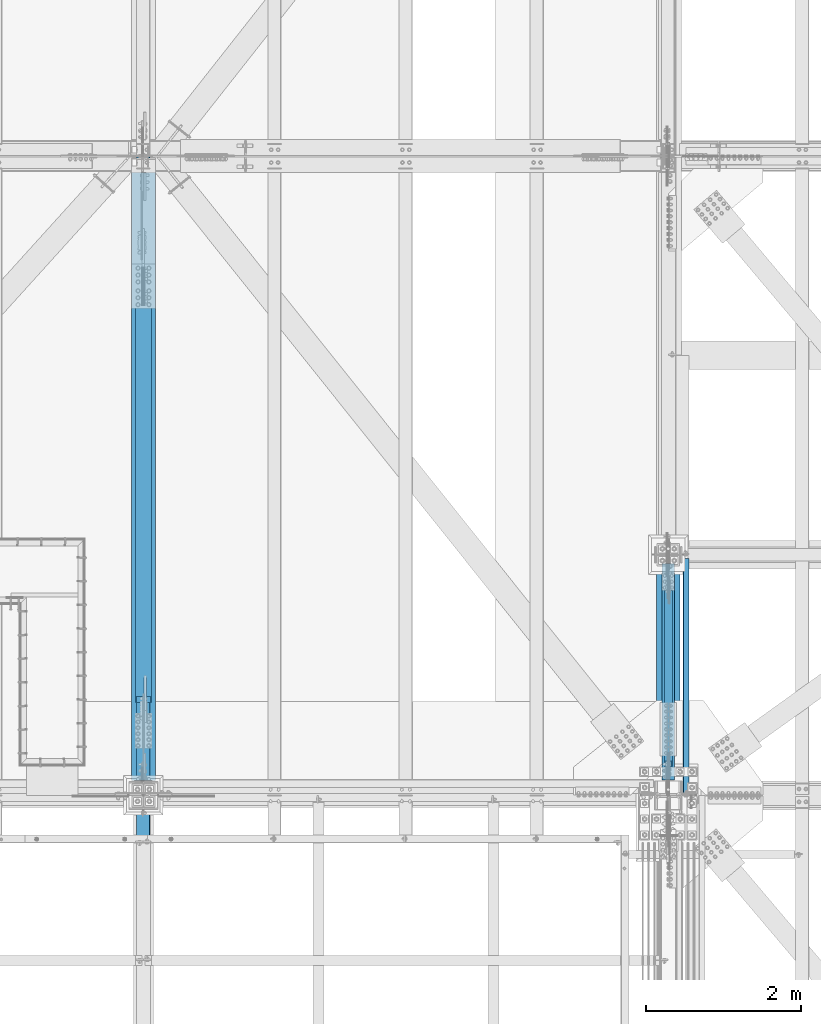
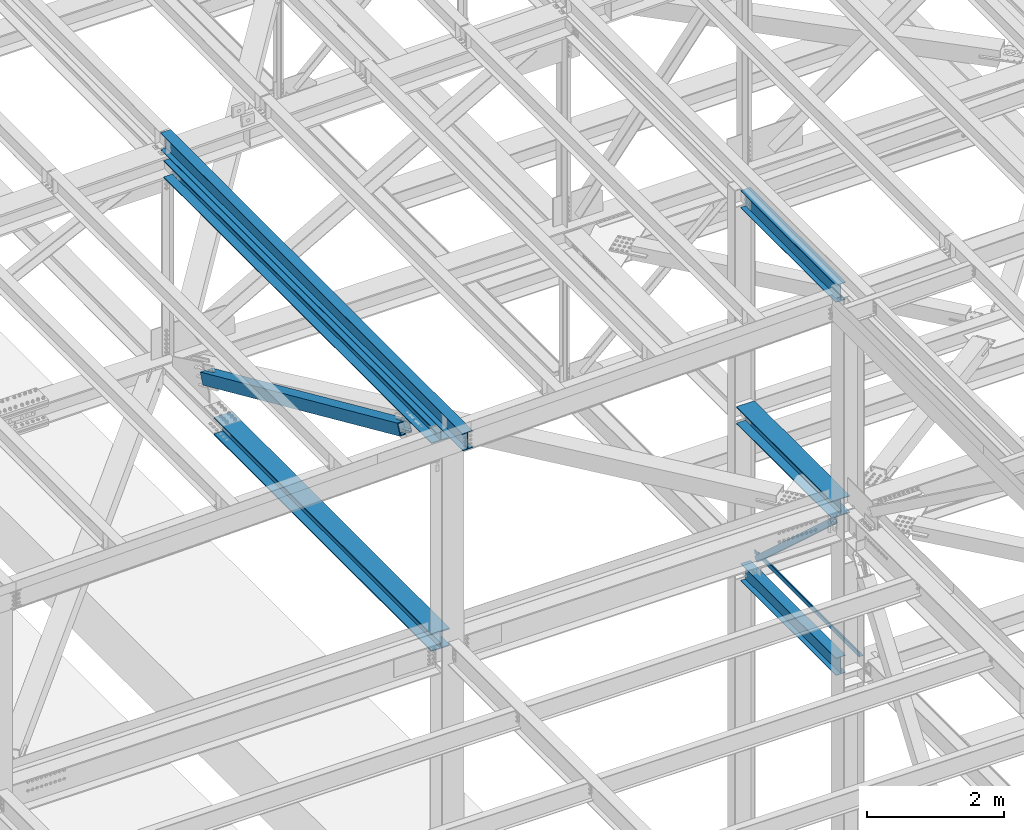
# One storey, part 1801 of 3843: 7 beams, 2 members, 9 elements without a shape of their own.
"""IFC2X3 building model written with IfcOpenShell, lengths in millimetres."""

from ifc_helpers import new_model, si_unit, frame, origin_with_axes, place, context, subcontext, project, spatial, faceted_brep, material, type_object, element, aggregate, save


model = new_model("IFC2X3")

# Units and contexts
model_context = context("Model", 3, precision=1e-05, world=origin_with_axes())
body_context = subcontext(model_context, "Body", "Model", "MODEL_VIEW")
ifc_project = project(units=[si_unit("LENGTHUNIT", "METRE", prefix="MILLI"), si_unit("AREAUNIT", "SQUARE_METRE"), si_unit("VOLUMEUNIT", "CUBIC_METRE"), si_unit("MASSUNIT", "GRAM", prefix="KILO"), si_unit("TIMEUNIT", "SECOND"), si_unit("PLANEANGLEUNIT", "RADIAN"), si_unit("SOLIDANGLEUNIT", "STERADIAN"), si_unit("THERMODYNAMICTEMPERATUREUNIT", "DEGREE_CELSIUS"), si_unit("LUMINOUSINTENSITYUNIT", "LUMEN")], contexts=[model_context])

# Site, building, storey
site_placement = place(None, origin_with_axes())
site = spatial("IfcSite", under=ifc_project, at=site_placement, CompositionType="ELEMENT")
building_placement = place(site_placement, origin_with_axes())
building = spatial("IfcBuilding", under=site, at=building_placement, Name="Undefined", CompositionType="ELEMENT")
storey_placement = place(building_placement, origin_with_axes())
storey = spatial("IfcBuildingStorey", under=building, at=storey_placement, Name="Undefined", CompositionType="ELEMENT", Elevation=0.0)

# Assembly, beam
assembly_1_placement = place(storey_placement, origin_with_axes())
assembly_1 = element("IfcElementAssembly", 1, at=assembly_1_placement, inside=storey, Name="BEAM", AssemblyPlace="NOTDEFINED", PredefinedType="RIGID_FRAME")
ifc_material_1 = material(Name="STEEL/A992")
beam_type_1 = type_object("IfcBeamType", Name="W12X26", PredefinedType="NOTDEFINED")
beam_1_placement = place(assembly_1_placement, frame((77012.8000002526, 25615.9, 46076.9955507418), z_axis=(0.0, 0.0, 1.0), x_axis=(0.0, 1.0, 0.0)))
beam_1 = element("IfcBeam", 2, at=beam_1_placement, type_object=beam_type_1, material=ifc_material_1, Name="BEAM", ObjectType="W12X26", context=body_context, shape_type="Brep", body=[
    faceted_brep([(196.849999999984, -82.5500000000029, -155.574999999997), (196.849999999984, 82.5500000000029, -155.574999999997), (2984.5, 82.5500000000029, -155.574999999997), (2984.5, -82.5500000000029, -155.574999999997), (196.849999999984, -82.5500000000029, -146.050000000003), (196.849999999984, -3.17500000000291, -146.050000000003), (196.849999999984, -3.17500000000291, 146.050000000003), (196.849999999984, -82.5500000000029, 146.050000000003), (196.849999999984, -82.5500000000029, 155.574999999997), (196.849999999984, 82.5500000000029, 155.574999999997), (196.849999999984, 82.5500000000029, 146.050000000003), (196.849999999984, 3.17500000000291, 146.050000000003), (196.849999999984, 3.17500000000291, 118.21499999892), (196.849999999984, 3.17500000000291, -124.564999999908), (196.849999999984, 3.17500000000291, -146.050000000003), (196.849999999984, 82.5500000000029, -146.050000000003), (2984.5, -82.5500000000029, -146.050000000003), (2984.5, -3.17500000000291, -146.050000000003), (2984.5, -3.17500000000291, 146.050000000003), (2984.5, -82.5500000000029, 146.050000000003), (2984.5, -82.5500000000029, 155.574999999997), (2984.5, 82.5500000000029, 155.574999999997), (2984.5, 82.5500000000029, 146.050000000003), (2984.5, 3.17500000000291, 146.050000000003), (2984.5, 3.17500000000291, 118.214999998927), (2984.5, 3.17500000000291, -124.5649999999), (2984.5, 3.17500000000291, -146.050000000003), (2984.5, 82.5500000000029, -146.050000000003)], [[[0, 1, 2, 3]], [[0, 4, 5, 6, 7, 8, 9, 10, 11, 12, 13, 14, 15, 1]], [[5, 4, 16, 17]], [[6, 5, 17, 18]], [[7, 6, 18, 19]], [[8, 7, 19, 20]], [[9, 8, 20, 21]], [[10, 9, 21, 22]], [[11, 10, 22, 23]], [[14, 13, 12, 11, 23, 24, 25, 26]], [[15, 14, 26, 27]], [[1, 15, 27, 2]], [[26, 25, 24, 23, 22, 21, 20, 19, 18, 17, 16, 3, 2, 27]], [[4, 0, 3, 16]]]),
])
aggregate(assembly_1, [beam_1])

assembly_2_placement = place(storey_placement, origin_with_axes())
assembly_2 = element("IfcElementAssembly", 3, at=assembly_2_placement, inside=storey, Name="BEAM", AssemblyPlace="NOTDEFINED", PredefinedType="RIGID_FRAME")
beam_2_placement = place(assembly_2_placement, frame((70253.1092622703, 25006.014051209, 46286.4854782954), z_axis=(-0.0211520977514447, -0.0018380119996873, 0.999774579829175), x_axis=(0.0, 0.999998310099008, 0.00183842300018168)))
beam_2 = element("IfcBeam", 4, at=beam_2_placement, type_object=beam_type_1, material=ifc_material_1, Name="BEAM", ObjectType="W12X26", context=body_context, shape_type="Brep", body=[
    faceted_brep([(0.0, 82.5500000000029, -155.574999999997), (0.0, 82.5500000000029, -146.050000000003), (8826.5292130925, 82.5500000010506, -146.050000012059), (8826.51170600161, 82.5500000010943, -155.575000012053), (0.0, 3.17500000000291, -146.050000000003), (8826.53229971384, 3.17500000062864, -146.050000011834), (0.0, 3.17500000000291, 146.050000000003), (8827.06918383486, 3.1749999998865, 146.049999988158), (0.0, 82.5500000000029, 146.050000000003), (8827.06609721354, 82.5500000003231, 146.049999987932), (0.0, 82.5500000000029, 155.574999999997), (8827.08360430443, 82.5500000002939, 155.574999987926), (0.0, -82.5500000000029, 155.574999999997), (8827.09002447681, -82.5500000006141, 155.574999988392), (0.0, -82.5500000000029, 146.050000000003), (8827.0725173859, -82.5500000005704, 146.049999988398), (0.0, -3.17500000000291, 146.050000000003), (8827.06943076458, -3.17500000014843, 146.049999988179), (0.0, -3.17500000000291, -146.050000000003), (8826.53254664355, -3.17499999940628, -146.050000011819), (0.0, -82.5500000000029, -146.050000000003), (8826.53563326488, -82.5499999998428, -146.050000011594), (0.0, -82.5500000000029, -155.574999999997), (8826.51812617397, -82.5499999998283, -155.575000011588)], [[[0, 1, 2, 3]], [[1, 4, 5, 2]], [[4, 6, 7, 5]], [[6, 8, 9, 7]], [[8, 10, 11, 9]], [[10, 12, 13, 11]], [[12, 14, 15, 13]], [[14, 16, 17, 15]], [[16, 18, 19, 17]], [[18, 20, 21, 19]], [[20, 22, 23, 21]], [[22, 0, 3, 23]], [[5, 7, 9, 11, 13, 15, 17, 19, 21, 23, 3, 2]], [[22, 20, 18, 16, 14, 12, 10, 8, 6, 4, 1, 0]]]),
])
aggregate(assembly_2, [beam_2])

assembly_3_placement = place(storey_placement, origin_with_axes())
assembly_3 = element("IfcElementAssembly", 5, at=assembly_3_placement, inside=storey, Name="BEAM", AssemblyPlace="NOTDEFINED", PredefinedType="RIGID_FRAME")
beam_3_placement = place(assembly_3_placement, frame((77012.8, 25615.9, 39423.975), z_axis=(0.0, 0.0, 1.0), x_axis=(0.0, 1.0, 0.0)))
beam_3 = element("IfcBeam", 6, at=beam_3_placement, type_object=beam_type_1, material=ifc_material_1, Name="BEAM", ObjectType="W12X26", context=body_context, shape_type="Brep", body=[
    faceted_brep([(196.849999999984, -82.5500000000029, -155.574999999997), (196.849999999984, 82.5500000000029, -155.574999999997), (2984.5, 82.5500000000029, -155.574999999997), (2984.5, -82.5500000000029, -155.574999999997), (196.849999999984, -82.5500000000029, -146.050000000003), (196.849999999984, -3.17500000000291, -146.050000000003), (196.850000000006, -3.17500000000291, -111.864999999998), (196.850000000006, -3.17500000000291, 118.214999999997), (196.849999999984, -3.17500000000291, 146.050000000003), (196.849999999984, -82.5500000000029, 146.050000000003), (196.849999999984, -82.5500000000029, 155.574999999997), (196.849999999984, 82.5500000000029, 155.574999999997), (196.849999999984, 82.5500000000029, 146.050000000003), (196.849999999984, 3.17500000000291, 146.050000000003), (196.849999999984, 3.17500000000291, -146.050000000003), (196.849999999984, 82.5500000000029, -146.050000000003), (2984.5, -82.5500000000029, -146.050000000003), (2984.5, -3.17500000000291, -146.050000000003), (2984.50000000001, -3.17500000000291, -111.864999999998), (2984.50000000001, -3.17500000000291, 118.214999999997), (2984.5, -3.17500000000291, 146.050000000003), (2984.5, -82.5500000000029, 146.050000000003), (2984.5, -82.5500000000029, 155.574999999997), (2984.5, 82.5500000000029, 155.574999999997), (2984.5, 82.5500000000029, 146.050000000003), (2984.5, 3.17500000000291, 146.050000000003), (2984.5, 3.17500000000291, -146.050000000003), (2984.5, 82.5500000000029, -146.050000000003)], [[[0, 1, 2, 3]], [[0, 4, 5, 6, 7, 8, 9, 10, 11, 12, 13, 14, 15, 1]], [[5, 4, 16, 17]], [[8, 7, 6, 5, 17, 18, 19, 20]], [[9, 8, 20, 21]], [[10, 9, 21, 22]], [[11, 10, 22, 23]], [[12, 11, 23, 24]], [[13, 12, 24, 25]], [[14, 13, 25, 26]], [[15, 14, 26, 27]], [[1, 15, 27, 2]], [[26, 25, 24, 23, 22, 21, 20, 19, 18, 17, 16, 3, 2, 27]], [[4, 0, 3, 16]]]),
])
aggregate(assembly_3, [beam_3])

assembly_4_placement = place(storey_placement, origin_with_axes())
assembly_4 = element("IfcElementAssembly", 7, at=assembly_4_placement, inside=storey, Name="BENT_PLATE", AssemblyPlace="NOTDEFINED", PredefinedType="RIGID_FRAME")
ifc_material_2 = material(Name="STEEL/A36")
beam_type_2 = type_object("IfcBeamType", PredefinedType="NOTDEFINED")
beam_4_placement = place(assembly_4_placement, frame((77279.5000000002, 27139.9, 39627.1749999997), z_axis=(0.0, 1.0, 0.0), x_axis=(-1.0, 0.0, 0.0)))
beam_4 = element("IfcBeam", 8, at=beam_4_placement, type_object=beam_type_2, material=ifc_material_2, Name="BENT_PLATE", context=body_context, shape_type="Brep", body=[
    faceted_brep([(0.0, -3.17500000000291, -1524.0), (0.0, -3.17500000000291, 1524.0), (0.0, 3.17500000000291, 1524.0), (0.0, 3.17500000000291, -1524.0), (69.8500000002387, 3.17500000000291, 1524.0), (69.8500000002387, 3.17500000000291, -1524.0), (76.2000000002299, -3.17500000000291, -1524.0), (76.2000000002299, -3.17500000000291, 1524.0), (69.8500000003114, 73.0249999997832, 1524.0), (69.8500000003114, 73.0249999997832, -1524.0), (76.2000000003172, 73.0249999997686, 1524.0), (76.2000000003172, 73.0249999997686, -1524.0)], [[[0, 1, 2, 3]], [[3, 2, 4, 5]], [[1, 0, 6, 7]], [[5, 4, 8, 9]], [[4, 2, 1, 7, 10, 8]], [[7, 6, 11, 10]], [[6, 0, 3, 5, 9, 11]], [[10, 11, 9, 8]]]),
])
aggregate(assembly_4, [beam_4])

# Assembly, member
assembly_5_placement = place(storey_placement, origin_with_axes())
assembly_5 = element("IfcElementAssembly", 9, at=assembly_5_placement, inside=storey, AssemblyPlace="NOTDEFINED", PredefinedType="RIGID_FRAME")
ifc_material_3 = material()
member_type_1 = type_object("IfcMemberType", Name="HSS4X4X3/8", PredefinedType="NOTDEFINED")
member_1_placement = place(assembly_5_placement, frame((77012.8, 25615.9, 42246.55), z_axis=(1.0, 0.0, 0.0), x_axis=(0.0, 0.739288510044847, -0.673388817040846)))
member_1 = element("IfcMember", 10, at=member_1_placement, type_object=member_type_1, material=ifc_material_3, ObjectType="HSS4X4X3/8", context=body_context, shape_type="Brep", body=[
    faceted_brep([(3521.58607597838, -50.8000000018219, 4.76249999999709), (3521.58607597841, -41.2750000018423, 4.76249999999709), (3421.57357597422, -41.2750000017841, 4.76249999999709), (3421.57357597417, -50.800000001771, 4.76249999999709), (3418.53602622981, -41.2750000017841, 5.36670621068333), (3418.53602622976, -50.800000001771, 5.36670621068333), (3415.96091589853, -41.2750000017841, 7.08733992432826), (3415.96091589848, -50.8000000017637, 7.08733992432826), (3414.24028218489, -41.2750000017841, 9.66245025559328), (3414.24028218483, -50.8000000017637, 9.66245025559328), (3413.63607597419, -41.2750000017841, 12.6999999999971), (3413.63607597414, -50.8000000017637, 12.6999999999971), (3414.24028218489, -41.2750000017841, 15.7375497444009), (3414.24028218483, -50.8000000017637, 15.7375497444009), (3415.96091589853, -41.2750000017841, 18.3126600756659), (3415.96091589848, -50.8000000017637, 18.3126600756659), (3418.53602622981, -41.2750000017841, 20.0332937893108), (3418.53602622976, -50.800000001771, 20.0332937893108), (3421.57357597422, -41.2750000017841, 20.6374999999971), (3421.57357597417, -50.800000001771, 20.6374999999971), (3521.58607597838, -50.8000000018219, 20.6374999999971), (3521.58607597841, -41.2750000018423, 20.6374999999971), (3521.58607597861, 41.2749999980297, 4.76249999999709), (3521.58607597864, 50.7999999980093, 4.76249999999709), (3421.57357597472, 50.7999999980675, 4.76249999999709), (3421.57357597467, 41.2749999980806, 4.76249999999709), (3418.53602623031, 50.7999999980675, 5.36670621068333), (3418.53602623026, 41.2749999980879, 5.36670621068333), (3415.96091589903, 50.7999999980675, 7.08733992432826), (3415.96091589898, 41.2749999980879, 7.08733992432826), (3414.24028218539, 50.7999999980675, 9.66245025559328), (3414.24028218533, 41.2749999980879, 9.66245025559328), (3413.63607597469, 50.7999999980748, 12.6999999999971), (3413.63607597464, 41.2749999980879, 12.6999999999971), (3414.24028218539, 50.7999999980675, 15.7375497444009), (3414.24028218533, 41.2749999980879, 15.7375497444009), (3415.96091589903, 50.7999999980675, 18.3126600756659), (3415.96091589898, 41.2749999980879, 18.3126600756659), (3418.53602623031, 50.7999999980675, 20.0332937893108), (3418.53602623026, 41.2749999980879, 20.0332937893108), (3421.57357597472, 50.7999999980675, 20.6374999999971), (3421.57357597467, 41.2749999980806, 20.6374999999971), (3521.58607597861, 41.2749999980297, 20.6374999999971), (3521.58607597864, 50.7999999980093, 20.6374999999971), (554.495127844564, -41.275000000227, 41.2749999999942), (554.495127844764, 41.2749999996449, 41.2749999999942), (3521.58607597861, 41.2749999980297, 41.2749999999942), (3521.58607597841, -41.2750000018423, 41.2749999999942), (3521.58607597841, -41.2750000018423, -41.2749999999942), (554.495127844564, -41.275000000227, -41.2749999999942), (554.495127844564, -41.275000000227, 4.76249999999709), (654.507627846315, -41.2750000002852, 4.76249999999709), (657.545177590726, -41.2750000002852, 5.36670621068333), (660.120287921998, -41.2750000002852, 7.08733992432826), (661.840921635647, -41.2750000002852, 9.66245025559328), (662.445127846344, -41.2750000002852, 12.6999999999971), (661.840921635647, -41.2750000002852, 15.7375497444009), (660.120287921998, -41.2750000002852, 18.3126600756659), (657.545177590726, -41.2750000002852, 20.0332937893108), (654.507627846315, -41.2750000002852, 20.6374999999971), (554.495127844564, -41.275000000227, 20.6374999999971), (554.495127844764, 41.2749999996449, -41.2749999999942), (3521.58607597861, 41.2749999980297, -41.2749999999942), (554.495127844764, 41.2749999996449, 20.6374999999971), (554.495127844786, 50.7999999996246, 20.6374999999971), (654.507627846817, 50.7999999995664, 20.6374999999971), (654.507627846762, 41.2749999995867, 20.6374999999971), (657.545177591224, 50.7999999995664, 20.0332937893108), (657.545177591173, 41.2749999995867, 20.0332937893108), (660.1202879225, 50.7999999995664, 18.3126600756659), (660.120287922449, 41.2749999995867, 18.3126600756659), (661.840921636145, 50.7999999995664, 15.7375497444009), (661.840921636094, 41.2749999995867, 15.7375497444009), (662.445127846839, 50.7999999995664, 12.6999999999971), (662.445127846795, 41.2749999995794, 12.6999999999971), (661.840921636145, 50.7999999995664, 9.66245025559328), (661.840921636094, 41.2749999995867, 9.66245025559328), (660.1202879225, 50.7999999995664, 7.08733992432826), (660.120287922449, 41.2749999995867, 7.08733992432826), (657.545177591224, 50.7999999995664, 5.36670621068333), (657.545177591173, 41.2749999995867, 5.36670621068333), (654.507627846817, 50.7999999995664, 4.76249999999709), (654.507627846762, 41.2749999995867, 4.76249999999709), (554.495127844786, 50.7999999996246, 4.76249999999709), (554.495127844764, 41.2749999996449, 4.76249999999709), (554.495127844786, 50.7999999996246, -50.8000000000029), (554.495127844542, -50.8000000002139, -50.8000000000029), (554.495127844542, -50.8000000002139, 4.76249999999709), (654.50762784626, -50.8000000002648, 4.76249999999709), (657.545177590671, -50.8000000002648, 5.36670621068333), (660.120287921947, -50.8000000002648, 7.08733992432826), (661.840921635599, -50.8000000002794, 9.66245025559328), (662.445127846289, -50.8000000002721, 12.6999999999971), (661.840921635599, -50.8000000002794, 15.7375497444009), (660.120287921947, -50.8000000002648, 18.3126600756659), (657.545177590671, -50.8000000002648, 20.0332937893108), (654.50762784626, -50.8000000002648, 20.6374999999971), (554.495127844542, -50.8000000002139, 20.6374999999971), (554.495127844542, -50.8000000002139, 50.8000000000029), (554.495127844786, 50.7999999996246, 50.8000000000029), (3521.58607597838, -50.8000000018219, 50.8000000000029), (3521.58607597864, 50.7999999980093, 50.8000000000029), (3521.58607597864, 50.7999999980093, -50.8000000000029), (3521.58607597838, -50.8000000018219, -50.8000000000029)], [[[0, 1, 2, 3]], [[3, 2, 4, 5]], [[5, 4, 6, 7]], [[7, 6, 8, 9]], [[9, 8, 10, 11]], [[11, 10, 12, 13]], [[13, 12, 14, 15]], [[15, 14, 16, 17]], [[17, 16, 18, 19]], [[20, 19, 18, 21]], [[22, 23, 24, 25]], [[25, 24, 26, 27]], [[27, 26, 28, 29]], [[29, 28, 30, 31]], [[31, 30, 32, 33]], [[33, 32, 34, 35]], [[35, 34, 36, 37]], [[37, 36, 38, 39]], [[39, 38, 40, 41]], [[42, 41, 40, 43]], [[44, 45, 46, 47]], [[16, 14, 12, 10, 8, 6, 4, 2, 1, 48, 49, 50, 51, 52, 53, 54, 55, 56, 57, 58, 59, 60, 44, 47, 21, 18]], [[61, 49, 48, 62]], [[63, 64, 65, 66]], [[66, 65, 67, 68]], [[68, 67, 69, 70]], [[70, 69, 71, 72]], [[72, 71, 73, 74]], [[74, 73, 75, 76]], [[76, 75, 77, 78]], [[78, 77, 79, 80]], [[80, 79, 81, 82]], [[82, 81, 83, 84]], [[49, 61, 84, 83, 85, 86, 87, 50]], [[88, 51, 50, 87]], [[89, 52, 51, 88]], [[90, 53, 52, 89]], [[91, 54, 53, 90]], [[92, 55, 54, 91]], [[93, 56, 55, 92]], [[94, 57, 56, 93]], [[95, 58, 57, 94]], [[96, 59, 58, 95]], [[97, 60, 59, 96]], [[98, 99, 64, 63, 45, 44, 60, 97]], [[99, 98, 100, 101]], [[47, 46, 42, 43, 101, 100, 20, 21]], [[38, 36, 34, 32, 30, 28, 26, 24, 23, 102, 85, 83, 81, 79, 77, 75, 73, 71, 69, 67, 65, 64, 99, 101, 43, 40]], [[86, 85, 102, 103]], [[100, 98, 97, 96, 95, 94, 93, 92, 91, 90, 89, 88, 87, 86, 103, 0, 3, 5, 7, 9, 11, 13, 15, 17, 19, 20]], [[103, 102, 23, 22, 62, 48, 1, 0]], [[46, 45, 63, 66, 68, 70, 72, 74, 76, 78, 80, 82, 84, 61, 62, 22, 25, 27, 29, 31, 33, 35, 37, 39, 41, 42]]]),
])
aggregate(assembly_5, [member_1])

# Assembly, beam
assembly_6_placement = place(storey_placement, origin_with_axes())
assembly_6 = element("IfcElementAssembly", 11, at=assembly_6_placement, inside=storey, Name="BEAM", AssemblyPlace="NOTDEFINED", PredefinedType="RIGID_FRAME")
beam_type_3 = type_object("IfcBeamType", Name="W12X79", PredefinedType="NOTDEFINED")
beam_5_placement = place(assembly_6_placement, frame((70256.4, 25615.8999999924, 42246.5500038407), z_axis=(0.0, -0.00197596299957513, 0.999998047783207), x_axis=(0.0, 0.999998047783207, 0.00197596299957832)))
beam_5 = element("IfcBeam", 12, at=beam_5_placement, type_object=beam_type_3, material=ifc_material_1, Name="BEAM", ObjectType="W12X79", context=body_context, shape_type="Brep", body=[
    faceted_brep([(190.227466467022, -153.987500000003, -138.11249999993), (190.189824336496, -153.987500000003, -157.16249999994), (6546.86279347326, -153.987500000003, -157.162499994578), (6546.86279343517, -153.987500000003, -138.11249999456), (190.227466467022, -6.35000000000582, -138.11249999993), (6546.86279343517, -6.35000000000582, -138.11249999456), (190.773277359673, -6.35000000000582, 138.112500000258), (6546.86279288272, -6.35000000000582, 138.112500005613), (190.773277359673, -153.987500000003, 138.112500000258), (6546.86279288272, -153.987500000003, 138.112500005613), (190.810919490199, -153.987500000003, 157.16250000026), (6546.86279284462, -153.987500000003, 157.16250000563), (190.810919490199, 153.987500000003, 157.16250000026), (6546.86279284462, 153.987500000003, 157.16250000563), (190.773277359673, 153.987500000003, 138.112500000258), (6546.86279288272, 153.987500000003, 138.112500005613), (190.773277359673, 6.35000000000582, 138.112500000258), (6546.86279288272, 6.35000000000582, 138.112500005613), (190.227466467022, 6.35000000000582, -138.11249999993), (6546.86279343517, 6.35000000000582, -138.11249999456), (190.227466467022, 153.987500000003, -138.11249999993), (6546.86279343517, 153.987500000003, -138.11249999456), (190.189824336496, 153.987500000003, -157.16249999994), (6546.86279347326, 153.987500000003, -157.162499994578)], [[[0, 1, 2, 3]], [[4, 0, 3, 5]], [[6, 4, 5, 7]], [[8, 6, 7, 9]], [[10, 8, 9, 11]], [[12, 10, 11, 13]], [[14, 12, 13, 15]], [[16, 14, 15, 17]], [[18, 16, 17, 19]], [[20, 18, 19, 21]], [[1, 0, 4, 6, 8, 10, 12, 14, 16, 18, 20, 22]], [[1, 22, 23, 2]], [[19, 17, 15, 13, 11, 9, 7, 5, 3, 2, 23, 21]], [[22, 20, 21, 23]]]),
])
aggregate(assembly_6, [beam_5])

# Assembly, member
assembly_7_placement = place(storey_placement, origin_with_axes())
assembly_7 = element("IfcElementAssembly", 13, at=assembly_7_placement, inside=storey, AssemblyPlace="NOTDEFINED", PredefinedType="RIGID_FRAME")
member_type_2 = type_object("IfcMemberType", Name="HSS8X8X1/2", PredefinedType="NOTDEFINED")
member_2_placement = place(assembly_7_placement, frame((70256.4, 33845.5, 42262.8114042285), z_axis=(-1.0, 0.0, 0.0), x_axis=(0.0, -0.912577307944657, 0.408904214975198)))
member_2 = element("IfcMember", 14, at=member_2_placement, type_object=member_type_2, material=ifc_material_3, ObjectType="HSS8X8X1/2", context=body_context, shape_type="Brep", body=[
    faceted_brep([(1347.67603524624, -101.599999995481, 17.4624999999942), (1347.67603524629, -88.8999999954694, 17.4624999999942), (1600.08853561316, -88.8999999946036, 17.4624999999942), (1600.08853561313, -101.599999994623, 17.4624999999942), (1606.77114490473, -88.8999999945745, 16.1332463655126), (1606.77114490472, -101.599999994593, 16.1332463655126), (1612.4363875097, -88.8999999945599, 12.3478522781952), (1612.43638750968, -101.599999994579, 12.3478522781952), (1616.22178159695, -88.8999999945454, 6.68260967315291), (1616.22178159691, -101.599999994564, 6.68260967315291), (1600.08853561313, -101.599999994623, -17.4624999999942), (1600.08853561316, -88.8999999946036, -17.4624999999942), (1347.67603524629, -88.8999999954694, -17.4624999999942), (1347.67603524624, -101.599999995481, -17.4624999999942), (1606.77114490472, -101.599999994593, -16.1332463655126), (1606.77114490473, -88.8999999945745, -16.1332463655126), (1612.43638750968, -101.599999994579, -12.3478522781952), (1612.4363875097, -88.8999999945599, -12.3478522781952), (1616.22178159691, -101.599999994564, -6.68260967315291), (1616.22178159695, -88.8999999945454, -6.68260967315291), (1617.55103523137, -101.599999994557, 3.81463905796409e-07), (1617.5510352314, -88.8999999945381, 3.81463905796409e-07), (1347.6760352468, 88.900000004759, 17.4624999999942), (1347.67603524686, 101.600000004771, 17.4624999999942), (1600.08853561363, 101.600000005644, 17.4624999999942), (1600.0885356136, 88.9000000056249, 17.4624999999942), (1606.77114490523, 101.600000005658, 16.1332463655126), (1606.7711449052, 88.9000000056467, 16.1332463655126), (1612.43638751017, 101.600000005687, 12.3478522781952), (1612.43638751014, 88.9000000056612, 12.3478522781952), (1616.22178159743, 101.600000005702, 6.68260967315291), (1616.2217815974, 88.9000000056758, 6.68260967315291), (1600.0885356136, 88.9000000056249, -17.4624999999942), (1600.08853561363, 101.600000005644, -17.4624999999942), (1347.67603524686, 101.600000004771, -17.4624999999942), (1347.6760352468, 88.900000004759, -17.4624999999942), (1606.7711449052, 88.9000000056467, -16.1332463655126), (1606.77114490523, 101.600000005658, -16.1332463655126), (1612.43638751014, 88.9000000056612, -12.3478522781952), (1612.43638751017, 101.600000005687, -12.3478522781952), (1616.2217815974, 88.9000000056758, -6.68260967315291), (1616.22178159743, 101.600000005702, -6.68260967315291), (1617.55103523187, 88.9000000056758, 3.81463905796409e-07), (1617.5510352319, 101.600000005702, 3.81463905796409e-07), (1347.67603524629, -88.8999999954694, 88.8999999999942), (1347.6760352468, 88.900000004759, 88.8999999999942), (7664.35287926906, 88.9000000265069, 88.8999999999942), (7664.35287926854, -88.8999999737289, 88.8999999999942), (1347.67603524686, 101.600000004771, 101.600000000006), (7664.35287926911, 101.600000026511, 101.600000000006), (7664.35292589612, 101.599999979975, -6.35000000000582), (7411.94042551481, 101.599999980623, -6.35000000000582), (7405.25781622318, 101.599999980637, -7.6792536344874), (7399.59257361819, 101.599999980652, -11.4646477218048), (7395.8071795309, 101.599999980666, -17.1298903268471), (7394.47792589643, 101.599999980666, -23.8125003814639), (7395.8071795309, 101.599999980666, -30.4951096731529), (7399.59257361819, 101.599999980652, -36.1603522781952), (7405.25781622318, 101.599999980637, -39.9457463655126), (7411.94042551481, 101.599999980623, -41.2749999999942), (7664.35292589612, 101.599999979975, -41.2749999999942), (7664.35287926911, 101.600000026511, -101.600000000006), (1347.67603524686, 101.600000004771, -101.600000000006), (7664.35292589612, 88.8999999799998, -6.35000000000582), (7411.94042551483, 88.8999999806547, -6.35000000000582), (7405.25781622319, 88.8999999806765, -7.6792536344874), (7399.5925736182, 88.8999999806838, -11.4646477218048), (7395.80717953091, 88.8999999806911, -17.1298903268471), (7394.47792589644, 88.8999999806983, -23.8125003814639), (7395.80717953091, 88.8999999806911, -30.4951096731529), (7399.5925736182, 88.8999999806838, -36.1603522781952), (7405.25781622319, 88.8999999806765, -39.9457463655126), (7411.94042551483, 88.8999999806547, -41.2749999999942), (7664.35292589612, 88.8999999799998, -41.2749999999942), (1347.6760352468, 88.900000004759, -88.8999999999942), (1347.67603524629, -88.8999999954694, -88.8999999999942), (7664.35287926854, -88.8999999737289, -88.8999999999942), (7664.35287926906, 88.9000000265069, -88.8999999999942), (7405.25781622333, -101.600000018792, -7.6792536344874), (7405.25781622332, -88.9000000188244, -7.6792536344874), (7411.94042551496, -88.9000000188462, -6.35000000000582), (7411.94042551496, -101.600000018807, -6.35000000000582), (7399.59257361834, -101.600000018771, -11.4646477218048), (7399.59257361833, -88.9000000188171, -11.4646477218048), (7395.80717953106, -101.600000018763, -17.1298903268471), (7395.80717953105, -88.9000000188025, -17.1298903268471), (7394.47792589658, -101.600000018763, -23.8125003814639), (7394.47792589657, -88.9000000187953, -23.8125003814639), (7395.80717953106, -101.600000018763, -30.4951096731529), (7395.80717953105, -88.9000000188025, -30.4951096731529), (7399.59257361834, -101.600000018771, -36.1603522781952), (7399.59257361833, -88.9000000188171, -36.1603522781952), (7405.25781622333, -101.600000018792, -39.9457463655126), (7405.25781622332, -88.9000000188244, -39.9457463655126), (7411.94042551496, -101.600000018807, -41.2749999999942), (7411.94042551496, -88.9000000188462, -41.2749999999942), (7664.35292589612, -101.600000019454, -41.2749999999942), (7664.35292589612, -88.9000000194937, -41.2749999999942), (7664.35287926851, -101.599999973741, -101.600000000006), (1347.67603524624, -101.599999995481, -101.600000000006), (7664.35292589612, -88.9000000194937, -6.35000000000582), (7664.35292589612, -101.600000019454, -6.35000000000582), (7664.35287926851, -101.599999973741, 101.600000000006), (1347.67603524624, -101.599999995481, 101.600000000006)], [[[0, 1, 2, 3]], [[3, 2, 4, 5]], [[5, 4, 6, 7]], [[7, 6, 8, 9]], [[10, 11, 12, 13]], [[14, 15, 11, 10]], [[16, 17, 15, 14]], [[18, 19, 17, 16]], [[20, 21, 19, 18]], [[9, 8, 21, 20]], [[22, 23, 24, 25]], [[25, 24, 26, 27]], [[27, 26, 28, 29]], [[29, 28, 30, 31]], [[32, 33, 34, 35]], [[36, 37, 33, 32]], [[38, 39, 37, 36]], [[40, 41, 39, 38]], [[42, 43, 41, 40]], [[31, 30, 43, 42]], [[44, 45, 46, 47]], [[28, 26, 24, 23, 48, 49, 50, 51, 52, 53, 54, 55, 56, 57, 58, 59, 60, 61, 62, 34, 33, 37, 39, 41, 43, 30]], [[63, 64, 51, 50]], [[65, 52, 51, 64]], [[66, 53, 52, 65]], [[67, 54, 53, 66]], [[68, 55, 54, 67]], [[69, 56, 55, 68]], [[70, 57, 56, 69]], [[71, 58, 57, 70]], [[72, 59, 58, 71]], [[73, 60, 59, 72]], [[74, 75, 76, 77]], [[78, 79, 80, 81]], [[82, 83, 79, 78]], [[84, 85, 83, 82]], [[86, 87, 85, 84]], [[88, 89, 87, 86]], [[90, 91, 89, 88]], [[92, 93, 91, 90]], [[94, 95, 93, 92]], [[96, 97, 95, 94]], [[98, 61, 60, 73, 77, 76, 97, 96]], [[99, 62, 61, 98]], [[75, 74, 35, 34, 62, 99, 13, 12]], [[6, 4, 2, 1, 44, 47, 100, 80, 79, 83, 85, 87, 89, 91, 93, 95, 97, 76, 75, 12, 11, 15, 17, 19, 21, 8]], [[101, 81, 80, 100]], [[47, 46, 63, 50, 49, 102, 101, 100]], [[48, 103, 102, 49]], [[16, 14, 10, 13, 99, 98, 96, 94, 92, 90, 88, 86, 84, 82, 78, 81, 101, 102, 103, 0, 3, 5, 7, 9, 20, 18]], [[103, 48, 23, 22, 45, 44, 1, 0]], [[38, 36, 32, 35, 74, 77, 73, 72, 71, 70, 69, 68, 67, 66, 65, 64, 63, 46, 45, 22, 25, 27, 29, 31, 42, 40]]]),
])
aggregate(assembly_7, [member_2])

# Assembly, beam
assembly_8_placement = place(storey_placement, origin_with_axes())
assembly_8 = element("IfcElementAssembly", 15, at=assembly_8_placement, inside=storey, Name="BEAM", AssemblyPlace="NOTDEFINED", PredefinedType="RIGID_FRAME")
beam_type_4 = type_object("IfcBeamType", Name="W12X65", PredefinedType="NOTDEFINED")
beam_6_placement = place(assembly_8_placement, frame((70256.4, 25615.9000000006, 45950.2996849465), z_axis=(0.0, 0.0, 1.0), x_axis=(0.0, 1.0, 0.0)))
beam_6 = element("IfcBeam", 16, at=beam_6_placement, type_object=beam_type_4, material=ifc_material_1, Name="BEAM", ObjectType="W12X65", context=body_context, shape_type="Brep", body=[
    faceted_brep([(190.499999998636, -152.399999999994, -138.112500000003), (190.499999998636, -152.399999999994, -153.987500000003), (8016.87499999944, -152.399999999994, -153.987500000003), (8016.87499999944, -152.399999999994, -138.112500000003), (190.499999998636, -4.76249999999709, -138.112500000003), (8016.87499999944, -4.76249999999709, -138.112500000003), (190.499999998636, -4.76249999999709, 138.112500000003), (8016.87499999944, -4.76249999999709, 138.112500000003), (190.499999998636, -152.399999999994, 138.112500000003), (8016.87499999944, -152.399999999994, 138.112500000003), (190.499999998636, -152.399999999994, 153.987500000003), (8016.87499999944, -152.399999999994, 153.987500000003), (190.499999998636, 152.399999999994, 153.987500000003), (8016.87499999944, 152.399999999994, 153.987500000003), (190.499999998636, 152.399999999994, 138.112500000003), (8016.87499999944, 152.399999999994, 138.112500000003), (190.499999998636, 4.76249999999709, 138.112500000003), (8016.87499999944, 4.76249999999709, 138.112500000003), (190.499999998636, 4.76249999999709, -138.112500000003), (8016.87499999944, 4.76249999999709, -138.112500000003), (190.499999998636, 152.399999999994, -138.112500000003), (8016.87499999944, 152.399999999994, -138.112500000003), (190.499999998636, 152.399999999994, -153.987500000003), (8016.87499999944, 152.399999999994, -153.987500000003)], [[[0, 1, 2, 3]], [[4, 0, 3, 5]], [[6, 4, 5, 7]], [[8, 6, 7, 9]], [[10, 8, 9, 11]], [[12, 10, 11, 13]], [[14, 12, 13, 15]], [[16, 14, 15, 17]], [[18, 16, 17, 19]], [[20, 18, 19, 21]], [[1, 0, 4, 6, 8, 10, 12, 14, 16, 18, 20, 22]], [[1, 22, 23, 2]], [[19, 17, 15, 13, 11, 9, 7, 5, 3, 2, 23, 21]], [[22, 20, 21, 23]]]),
])
aggregate(assembly_8, [beam_6])

assembly_9_placement = place(storey_placement, origin_with_axes())
assembly_9 = element("IfcElementAssembly", 17, at=assembly_9_placement, inside=storey, Name="BEAM", AssemblyPlace="NOTDEFINED", PredefinedType="RIGID_FRAME")
beam_7_placement = place(assembly_9_placement, frame((77012.8, 25615.9, 42246.55), z_axis=(0.0, 0.0, 1.0), x_axis=(0.0, 1.0, 0.0)))
beam_7 = element("IfcBeam", 18, at=beam_7_placement, type_object=beam_type_4, material=ifc_material_1, Name="BEAM", ObjectType="W12X65", context=body_context, shape_type="Brep", body=[
    faceted_brep([(196.849999999762, 147.637500000012, -153.987500000003), (196.849999999762, -147.637499999983, -153.987500000003), (196.849999999165, -152.400000000001, -153.987500000003), (196.849999999165, -152.400000000001, -138.112500000003), (196.849999999762, -147.637499999983, -138.112500000003), (196.849999999165, -4.76249999999709, -138.112500000003), (196.849999999165, -4.76249999999709, 138.112500000003), (196.849999999762, -147.637499999983, 138.112500000003), (196.849999999165, -152.400000000001, 138.112500000003), (196.849999999165, -152.400000000001, 153.987500000003), (196.849999999762, -147.637499999983, 153.987500000003), (196.849999999762, 147.637500000012, 153.987500000003), (196.849999999165, 152.400000000001, 153.987500000003), (196.849999999165, 152.400000000001, 138.112500000003), (196.849999999762, 147.637500000012, 138.112500000003), (196.849999999165, 4.76249999999709, 138.112500000003), (196.849999999762, 4.76249999999709, 116.627499998991), (196.849999999762, 4.76249999999709, -113.452499999905), (196.849999999165, 4.76249999999709, -138.112500000003), (196.849999999762, 147.637500000012, -138.112500000003), (196.849999999165, 152.400000000001, -138.112500000003), (196.849999999165, 152.400000000001, -153.987500000003), (2984.50000000006, -152.399999999994, -153.987500000003), (2984.50000000006, -152.399999999994, -138.112500000003), (2984.50000000006, -146.050000000017, -138.112500000003), (2984.50000000006, -4.76249999999709, -138.112500000003), (2984.50000000006, -4.76249999999709, 138.112500000003), (2984.50000000006, -146.050000000017, 138.112500000003), (2984.50000000006, -152.399999999994, 138.112500000003), (2984.50000000006, -152.399999999994, 153.987500000003), (2984.50000000006, -146.050000000017, 153.987500000003), (2984.50000000006, 146.049999999988, 153.987500000003), (2984.50000000006, 152.399999999994, 153.987500000003), (2984.50000000006, 152.399999999994, 138.112500000003), (2984.50000000006, 146.049999999988, 138.112500000003), (2984.50000000006, 4.76249999999709, 138.112500000003), (2984.50000000006, 4.76249999999709, 116.627499999995), (2984.50000000006, 4.76249999999709, -113.452499999999), (2984.50000000006, 4.76249999999709, -138.112500000003), (2984.50000000006, 146.049999999988, -138.112500000003), (2984.50000000006, 152.399999999994, -138.112500000003), (2984.50000000006, 152.399999999994, -153.987500000003), (2984.50000000006, -146.050000000017, -153.987500000003), (2984.50000000006, 146.049999999988, -153.987500000003)], [[[0, 1, 2, 3, 4, 5, 6, 7, 8, 9, 10, 11, 12, 13, 14, 15, 16, 17, 18, 19, 20, 21]], [[3, 2, 22, 23]], [[5, 4, 3, 23, 24, 25]], [[6, 5, 25, 26]], [[8, 7, 6, 26, 27, 28]], [[9, 8, 28, 29]], [[12, 11, 10, 9, 29, 30, 31, 32]], [[13, 12, 32, 33]], [[15, 14, 13, 33, 34, 35]], [[18, 17, 16, 15, 35, 36, 37, 38]], [[20, 19, 18, 38, 39, 40]], [[21, 20, 40, 41]], [[39, 38, 37, 36, 35, 34, 33, 32, 31, 30, 29, 28, 27, 26, 25, 24, 23, 22, 42, 43, 41, 40]], [[2, 1, 0, 21, 41, 43, 42, 22]]]),
])
aggregate(assembly_9, [beam_7])

save(model, "model.ifc")
